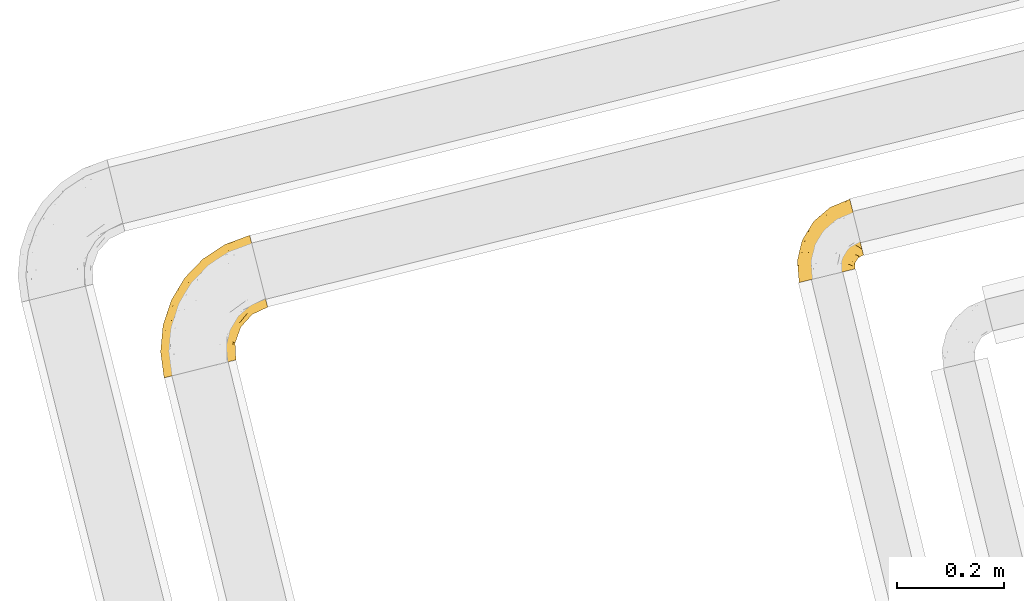
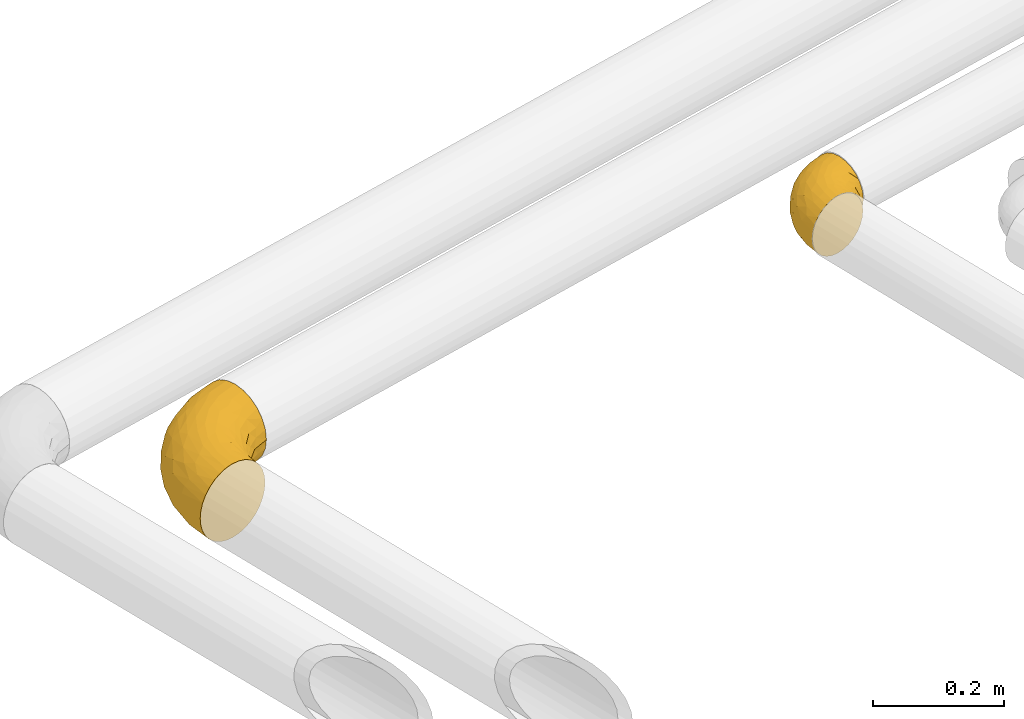
# One storey, part 11 of 93: 2 coverings.
"""IFC2X3 building model written with IfcOpenShell, lengths in millimetres."""

from ifc_helpers import new_model, entity, si_unit, converted_unit, derived_unit, direction, frame, origin, place, context, subcontext, project, spatial, faceted_brep, element, save


model = new_model("IFC2X3")

# Units and contexts
model_context = context("Model", 3, precision=0.01, world=origin(), true_north=direction((6.12303176911189e-17, 1.0)))
body_context = subcontext(model_context, "Body", "Model", "MODEL_VIEW")
ifc_project = project(units=[si_unit("LENGTHUNIT", "METRE", prefix="MILLI"), si_unit("AREAUNIT", "SQUARE_METRE"), si_unit("VOLUMEUNIT", "CUBIC_METRE"), converted_unit("PLANEANGLEUNIT", "DEGREE", entity("IfcRatioMeasure", 0.0174532925199433), si_unit("PLANEANGLEUNIT", "RADIAN"), dimensions=[0, 0, 0, 0, 0, 0, 0]), si_unit("MASSUNIT", "GRAM", prefix="KILO"), derived_unit("MASSDENSITYUNIT", [(si_unit("MASSUNIT", "GRAM", prefix="KILO"), 1), (si_unit("LENGTHUNIT", "METRE"), -3)]), derived_unit("MOMENTOFINERTIAUNIT", [(si_unit("LENGTHUNIT", "METRE"), 4)]), si_unit("TIMEUNIT", "SECOND"), si_unit("FREQUENCYUNIT", "HERTZ"), si_unit("THERMODYNAMICTEMPERATUREUNIT", "DEGREE_CELSIUS"), derived_unit("THERMALTRANSMITTANCEUNIT", [(si_unit("MASSUNIT", "GRAM", prefix="KILO"), 1), (si_unit("THERMODYNAMICTEMPERATUREUNIT", "KELVIN"), -1), (si_unit("TIMEUNIT", "SECOND"), -3)]), derived_unit("VOLUMETRICFLOWRATEUNIT", [(si_unit("LENGTHUNIT", "METRE"), 3), (si_unit("TIMEUNIT", "SECOND"), -1)]), derived_unit("MASSFLOWRATEUNIT", [(si_unit("MASSUNIT", "GRAM", prefix="KILO"), 1), (si_unit("TIMEUNIT", "SECOND"), -1)]), derived_unit("ROTATIONALFREQUENCYUNIT", [(si_unit("TIMEUNIT", "SECOND"), -1)]), si_unit("ELECTRICCURRENTUNIT", "AMPERE"), si_unit("ELECTRICVOLTAGEUNIT", "VOLT"), si_unit("POWERUNIT", "WATT"), si_unit("FORCEUNIT", "NEWTON", prefix="KILO"), si_unit("ILLUMINANCEUNIT", "LUX"), si_unit("LUMINOUSFLUXUNIT", "LUMEN"), si_unit("LUMINOUSINTENSITYUNIT", "CANDELA"), derived_unit("USERDEFINED", [(si_unit("MASSUNIT", "GRAM", prefix="KILO"), -1), (si_unit("LENGTHUNIT", "METRE"), -2), (si_unit("TIMEUNIT", "SECOND"), 3), (si_unit("LUMINOUSFLUXUNIT", "LUMEN"), 1)]), derived_unit("LINEARVELOCITYUNIT", [(si_unit("LENGTHUNIT", "METRE"), 1), (si_unit("TIMEUNIT", "SECOND"), -1)]), si_unit("PRESSUREUNIT", "PASCAL"), derived_unit("USERDEFINED", [(si_unit("LENGTHUNIT", "METRE"), -2), (si_unit("MASSUNIT", "GRAM", prefix="KILO"), 1), (si_unit("TIMEUNIT", "SECOND"), -2)]), derived_unit("LINEARFORCEUNIT", [(si_unit("MASSUNIT", "GRAM", prefix="KILO"), 1), (si_unit("LENGTHUNIT", "METRE"), 1), (si_unit("TIMEUNIT", "SECOND"), -2), (si_unit("LENGTHUNIT", "METRE"), -1)]), derived_unit("PLANARFORCEUNIT", [(si_unit("MASSUNIT", "GRAM", prefix="KILO"), 1), (si_unit("LENGTHUNIT", "METRE"), 1), (si_unit("TIMEUNIT", "SECOND"), -2), (si_unit("LENGTHUNIT", "METRE"), -2)])], contexts=[model_context])

# Site, building, storey
site_placement = place(None, origin())
site = spatial("IfcSite", under=ifc_project, at=site_placement, CompositionType="ELEMENT")
building_placement = place(site_placement, origin())
building = spatial("IfcBuilding", under=site, at=building_placement, CompositionType="ELEMENT")
storey_placement = place(building_placement, frame((0.0, 0.0, -4200.0)))
storey = spatial("IfcBuildingStorey", under=building, at=storey_placement, CompositionType="ELEMENT", Elevation=-4200.0)

# Coverings
covering_1_placement = place(storey_placement, frame((-16617.81, 11360.72, 2429.32)))
element("IfcCovering", 1, at=covering_1_placement, inside=storey, Name=":ADSK_", ObjectType=":ADSK_", PredefinedType="INSULATION", context=body_context, shape_type="Brep", body=[
    faceted_brep([(27.66, 6.48, 119.38), (19.34, 4.41, 108.92), (13.15, 2.87, 96.99), (9.34, 1.92, 84.05), (8.06, 1.6, 70.6), (9.34, 1.92, 57.13), (13.16, 2.87, 44.18), (19.34, 4.41, 32.25), (27.67, 6.49, 21.8), (37.82, 9.02, 13.22), (49.39, 11.9, 6.84), (61.95, 15.03, 2.92), (75.01, 18.29, 1.6), (88.07, 21.55, 2.92), (100.63, 24.68, 6.85), (112.21, 27.56, 13.23), (122.35, 30.09, 21.81), (130.68, 32.17, 32.27), (136.86, 33.71, 44.2), (140.67, 34.66, 57.14), (141.96, 34.98, 70.6), (140.67, 34.66, 84.06), (136.86, 33.71, 97.01), (130.67, 32.17, 108.94), (122.34, 30.09, 119.39), (112.2, 27.56, 127.97), (100.62, 24.67, 134.35), (88.06, 21.54, 138.27), (75.01, 18.29, 139.6), (61.94, 15.03, 138.27), (49.38, 11.9, 134.34), (37.8, 9.01, 127.96), (198.72, 142.14, 36.1), (196.07, 152.78, 21.8), (192.61, 166.65, 10.84), (188.58, 182.79, 3.95), (186.7, 190.35, 2.92), (184.26, 200.12, 1.6), (179.94, 217.45, 3.95), (175.92, 233.6, 10.84), (172.46, 247.46, 21.8), (169.81, 258.1, 36.1), (168.14, 264.79, 52.74), (167.57, 267.07, 70.6), (168.14, 264.79, 88.45), (169.81, 258.1, 105.1), (172.46, 247.46, 119.39), (175.92, 233.6, 130.35), (179.94, 217.45, 137.24), (184.26, 200.12, 139.6), (186.7, 190.35, 138.27), (188.58, 182.79, 137.24), (192.61, 166.65, 130.35), (196.07, 152.78, 119.39), (198.72, 142.14, 105.1), (200.39, 135.45, 88.45), (200.96, 133.17, 70.6), (200.39, 135.45, 52.74), (80.62, 223.04, 70.6), (94.81, 232.4, 83.48), (121.61, 249.95, 70.6), (128.34, 251.82, 83.77), (60.54, 84.03, 138.42), (59.59, 48.09, 138.7), (70.57, 57.19, 139.6), (115.53, 241.59, 95.16), (46.64, 187.68, 70.6), (21.38, 145.64, 70.6), (34.87, 166.15, 88.55), (46.46, 70.33, 134.98), (34.07, 62.13, 129.07), (131.53, 214.73, 131.06), (110.47, 216.17, 122.45), (92.11, 189.92, 129.1), (63.88, 205.82, 83.61), (55.22, 147.52, 127.05), (74.12, 184.86, 122.02), (44.71, 151.47, 117.32), (39.65, 108.08, 127.76), (128.35, 238.9, 110.77), (54.14, 178.89, 108.41), (84.27, 208.01, 111.97), (145.82, 233.08, 124.14), (89.6, 155.91, 137.81), (91.98, 131.83, 139.6), (104.16, 147.15, 139.6), (116.35, 162.48, 139.6), (10.95, 89.14, 99.97), (22.07, 108.68, 111.29), (24.2, 135.36, 100.2), (142.23, 204.2, 136.96), (24.84, 79.64, 120.82), (107.9, 189.12, 134.72), (119.98, 181.7, 138.53), (132.09, 174.12, 139.6), (147.83, 185.77, 139.6), (13.81, 121.67, 85.56), (4.85, 85.24, 83.03), (68.01, 203.39, 98.49), (25.6, 40.79, 122.52), (15.87, 48.45, 112.56), (4.16, 50.71, 89.27), (1.6, 50.21, 70.6), (8.86, 51.21, 101.45), (73.06, 35.38, 139.6), (59.32, 128.79, 133.88), (72.83, 121.4, 138.52), (73.47, 76.56, 139.6), (76.36, 95.92, 139.6), (77.59, 164.24, 132.65), (6.11, 99.04, 70.6), (84.17, 113.88, 139.6), (158.04, 189.79, 139.6), (168.26, 193.82, 139.6), (136.37, 67.44, 94.19), (129.76, 53.94, 106.02), (162.45, 171.59, 136.83), (95.65, 56.81, 134.87), (107.32, 80.2, 130.69), (86.68, 78.41, 138.16), (128.8, 133.71, 133.28), (142.9, 131.05, 126.08), (146.48, 146.13, 131.6), (120.17, 60.65, 118.74), (128.13, 75.11, 111.83), (121.81, 91.54, 123.27), (129.41, 151.89, 137.55), (148.99, 159.57, 135.67), (110.29, 50.65, 127.06), (108.93, 102.01, 133.33), (111.74, 129.23, 137.19), (95.79, 106.47, 137.97), (171.82, 155.75, 128.39), (163.85, 122.49, 101.84), (178.04, 125.7, 86.49), (183.03, 133.25, 99.1), (138.11, 85.23, 100.79), (158.88, 109.83, 86.27), (135.48, 95.69, 111.58), (172.37, 119.69, 70.6), (151.12, 96.29, 70.6), (169.02, 138.92, 116.89), (144.83, 88.41, 86.82), (140.44, 66.55, 70.6), (85.37, 42.83, 138.09), (146.9, 120.39, 116.82), (147.53, 102.49, 99.48), (123.26, 115.61, 129.97), (132.17, 108.77, 121.73), (157.74, 141.91, 125.02), (143.29, 90.33, 47.08), (154.25, 106.81, 49.2), (107.7, 68.0, 11.95), (96.92, 51.72, 6.82), (92.37, 81.84, 4.25), (168.73, 119.6, 53.51), (157.29, 117.18, 38.34), (178.78, 131.41, 41.46), (171.82, 155.75, 12.8), (166.39, 137.69, 23.89), (146.48, 146.13, 9.59), (107.88, 95.25, 8.56), (121.57, 78.45, 21.21), (140.05, 106.42, 27.96), (141.23, 124.14, 17.86), (153.79, 124.17, 27.1), (135.82, 57.93, 48.02), (129.8, 70.63, 32.97), (183.7, 129.24, 53.08), (131.25, 89.06, 27.99), (120.7, 55.5, 23.19), (130.17, 50.25, 35.67), (85.38, 42.84, 3.1), (162.45, 171.59, 4.37), (176.26, 196.97, 1.6), (147.83, 185.77, 1.6), (168.26, 193.82, 1.6), (138.24, 163.46, 2.93), (132.09, 174.12, 1.6), (123.96, 146.26, 3.68), (124.47, 100.29, 17.11), (121.62, 124.69, 7.87), (111.29, 46.6, 14.69), (84.3, 63.94, 2.91), (70.57, 57.19, 1.6), (73.06, 35.38, 1.6), (95.32, 109.04, 2.92), (76.36, 95.92, 1.6), (84.17, 113.88, 1.6), (91.98, 131.83, 1.6), (73.47, 76.56, 1.6), (106.98, 128.07, 3.18), (104.16, 147.15, 1.6), (116.35, 162.48, 1.6), (90.11, 155.74, 3.26), (69.46, 122.71, 3.41), (61.03, 132.13, 7.26), (36.84, 94.34, 12.98), (35.14, 53.42, 11.38), (24.85, 79.65, 20.36), (22.1, 108.75, 29.89), (15.88, 48.46, 28.62), (10.96, 89.18, 41.21), (151.59, 201.48, 2.7), (51.33, 53.64, 4.33), (24.19, 135.37, 41.0), (60.86, 83.69, 2.7), (103.02, 236.55, 52.64), (132.45, 253.79, 57.93), (136.93, 251.76, 45.26), (13.81, 121.67, 55.63), (122.65, 236.15, 30.68), (132.63, 211.56, 8.42), (25.61, 40.8, 18.66), (63.88, 205.82, 57.58), (68.01, 203.39, 42.7), (115.79, 184.23, 3.64), (108.97, 235.23, 41.02), (34.87, 166.15, 52.64), (44.02, 171.36, 39.64), (33.24, 117.03, 20.5), (48.52, 91.07, 6.62), (140.19, 230.96, 17.3), (101.64, 210.45, 19.21), (103.38, 189.76, 7.94), (71.28, 177.86, 17.12), (78.85, 162.39, 7.56), (6.3, 86.93, 52.86), (9.58, 38.2, 39.53), (4.17, 50.73, 51.91), (44.74, 151.51, 23.86), (69.03, 191.86, 28.24), (51.91, 138.11, 13.13), (90.48, 216.82, 33.14)], [[[0, 1, 2, 3, 4, 5, 6, 7, 8, 9, 10, 11, 12, 13, 14, 15, 16, 17, 18, 19, 20, 21, 22, 23, 24, 25, 26, 27, 28, 29, 30, 31]], [[32, 33, 34, 35, 36, 37, 38, 39, 40, 41, 42, 43, 44, 45, 46, 47, 48, 49, 50, 51, 52, 53, 54, 55, 56, 57]], [[58, 59, 60]], [[61, 43, 60]], [[62, 63, 64]], [[44, 65, 45]], [[66, 67, 68]], [[69, 70, 30]], [[71, 72, 73]], [[58, 74, 59]], [[75, 76, 77]], [[74, 58, 66]], [[77, 78, 75]], [[79, 46, 45]], [[80, 76, 81]], [[79, 45, 65]], [[47, 46, 82]], [[83, 84, 85, 86]], [[87, 88, 89]], [[49, 48, 90]], [[91, 70, 78]], [[90, 92, 93]], [[93, 86, 94, 95]], [[87, 96, 97]], [[74, 68, 98]], [[78, 70, 69]], [[70, 91, 99]], [[0, 99, 100]], [[2, 101, 3]], [[102, 101, 97]], [[81, 79, 65]], [[1, 100, 103]], [[68, 96, 89]], [[2, 1, 103]], [[59, 61, 60]], [[102, 4, 3]], [[86, 93, 83]], [[99, 0, 31]], [[68, 89, 80]], [[63, 69, 29]], [[63, 28, 104, 64]], [[92, 90, 71]], [[101, 103, 87]], [[69, 30, 29]], [[105, 62, 106]], [[62, 64, 107, 108]], [[88, 100, 91]], [[83, 106, 84]], [[1, 0, 100]], [[109, 83, 92]], [[96, 67, 110]], [[96, 68, 67]], [[106, 108, 111, 84]], [[102, 3, 101]], [[105, 69, 62]], [[90, 95, 112, 113, 49]], [[83, 93, 92]], [[97, 96, 110]], [[89, 96, 87]], [[95, 90, 93]], [[71, 48, 47]], [[48, 71, 90]], [[82, 71, 47]], [[81, 65, 98]], [[82, 79, 72]], [[31, 30, 70]], [[100, 99, 91]], [[70, 99, 31]], [[78, 69, 105]], [[75, 78, 105]], [[88, 78, 77]], [[87, 100, 88]], [[77, 76, 80]], [[78, 88, 91]], [[77, 89, 88]], [[68, 74, 66]], [[59, 98, 65]], [[105, 109, 75]], [[73, 76, 75]], [[75, 109, 73]], [[81, 76, 72]], [[79, 81, 72]], [[81, 98, 80]], [[83, 109, 105]], [[109, 92, 73]], [[68, 80, 98]], [[89, 77, 80]], [[98, 59, 74]], [[59, 65, 61]], [[65, 44, 61]], [[43, 61, 44]], [[71, 73, 92]], [[72, 76, 73]], [[69, 63, 62]], [[28, 63, 29]], [[105, 106, 83]], [[108, 106, 62]], [[79, 82, 46]], [[71, 82, 72]], [[2, 103, 101]], [[100, 87, 103]], [[102, 97, 110]], [[87, 97, 101]], [[22, 114, 115]], [[116, 112, 95]], [[116, 51, 112]], [[117, 118, 119]], [[52, 51, 116]], [[120, 121, 122]], [[123, 124, 125]], [[94, 126, 127]], [[117, 25, 128]], [[129, 130, 131]], [[124, 123, 115]], [[53, 52, 132]], [[133, 134, 135]], [[84, 131, 130]], [[114, 136, 124]], [[56, 55, 134]], [[134, 133, 137]], [[124, 136, 138]], [[139, 137, 140]], [[54, 53, 141]], [[123, 23, 115]], [[94, 86, 126]], [[24, 128, 25]], [[142, 143, 140]], [[117, 26, 25]], [[123, 24, 23]], [[132, 141, 53]], [[26, 144, 27]], [[144, 104, 27]], [[23, 22, 115]], [[133, 141, 145]], [[118, 128, 123]], [[143, 21, 20]], [[143, 114, 21]], [[141, 133, 135]], [[136, 142, 146]], [[119, 144, 117]], [[137, 142, 140]], [[21, 114, 22]], [[119, 131, 108]], [[118, 117, 128]], [[126, 85, 130]], [[26, 117, 144]], [[128, 24, 123]], [[107, 144, 119]], [[116, 127, 132]], [[107, 119, 108]], [[64, 144, 107]], [[131, 84, 111, 108]], [[119, 118, 131]], [[131, 118, 129]], [[125, 118, 123]], [[138, 146, 145]], [[147, 120, 130]], [[120, 126, 130]], [[114, 124, 115]], [[124, 138, 125]], [[148, 138, 145]], [[129, 125, 147]], [[116, 132, 52]], [[132, 122, 149]], [[121, 149, 122]], [[125, 148, 147]], [[134, 137, 139]], [[133, 145, 146]], [[146, 142, 137]], [[143, 142, 114]], [[133, 146, 137]], [[136, 146, 138]], [[56, 134, 139]], [[134, 55, 135]], [[55, 54, 135]], [[141, 135, 54]], [[104, 144, 64]], [[104, 28, 27]], [[142, 136, 114]], [[50, 49, 113, 112, 51]], [[116, 95, 94]], [[125, 129, 118]], [[130, 129, 147]], [[147, 148, 121]], [[126, 120, 122]], [[127, 126, 122]], [[138, 148, 125]], [[147, 121, 120]], [[149, 145, 141]], [[145, 149, 121]], [[132, 149, 141]], [[132, 127, 122]], [[94, 127, 116]], [[85, 126, 86]], [[85, 84, 130]], [[121, 148, 145]], [[140, 150, 151]], [[152, 153, 154]], [[155, 156, 157]], [[158, 159, 160]], [[152, 161, 162]], [[163, 164, 165]], [[166, 167, 150]], [[155, 168, 139]], [[167, 162, 169]], [[170, 167, 171]], [[13, 172, 14]], [[155, 151, 156]], [[34, 173, 35]], [[174, 37, 36, 35, 175, 176]], [[143, 19, 166]], [[34, 33, 158]], [[143, 150, 140]], [[173, 177, 178]], [[33, 32, 159]], [[166, 150, 143]], [[160, 179, 177]], [[143, 20, 19]], [[161, 180, 162]], [[179, 160, 181]], [[171, 166, 18]], [[32, 57, 157]], [[18, 166, 19]], [[15, 182, 16]], [[16, 170, 17]], [[153, 15, 14]], [[161, 152, 154]], [[183, 172, 184]], [[170, 162, 167]], [[153, 152, 182]], [[181, 164, 180]], [[180, 161, 181]], [[182, 170, 16]], [[184, 172, 185]], [[172, 13, 185]], [[157, 159, 32]], [[164, 163, 180]], [[186, 187, 188, 189]], [[18, 17, 171]], [[158, 173, 34]], [[183, 153, 172]], [[170, 171, 17]], [[166, 171, 167]], [[190, 187, 183, 184]], [[153, 14, 172]], [[183, 187, 154]], [[139, 168, 56]], [[157, 156, 165]], [[153, 182, 15]], [[170, 182, 152]], [[168, 155, 157]], [[140, 155, 139]], [[154, 186, 161]], [[160, 159, 164]], [[191, 161, 186]], [[191, 192, 179]], [[187, 186, 154]], [[191, 186, 189]], [[159, 158, 33]], [[173, 158, 160]], [[160, 164, 181]], [[165, 164, 159]], [[156, 150, 163]], [[169, 150, 167]], [[13, 12, 185]], [[152, 162, 170]], [[169, 180, 163]], [[180, 169, 162]], [[150, 169, 163]], [[154, 153, 183]], [[179, 181, 191]], [[177, 179, 193]], [[178, 175, 173]], [[160, 177, 173]], [[177, 193, 178]], [[161, 191, 181]], [[140, 151, 155]], [[150, 156, 151]], [[175, 35, 173]], [[157, 57, 168]], [[56, 168, 57]], [[157, 165, 159]], [[163, 165, 156]], [[192, 191, 189]], [[192, 193, 179]], [[194, 195, 196]], [[197, 198, 199]], [[200, 201, 202]], [[203, 37, 174, 176, 175]], [[198, 204, 10]], [[200, 202, 205]], [[206, 187, 190, 184]], [[189, 195, 194]], [[58, 60, 207]], [[8, 7, 201]], [[43, 42, 208]], [[209, 207, 208]], [[67, 210, 110]], [[211, 41, 40]], [[205, 202, 210]], [[203, 212, 38]], [[213, 198, 9]], [[214, 207, 215]], [[216, 175, 178, 193]], [[207, 209, 217]], [[218, 219, 205]], [[200, 220, 199]], [[195, 206, 221]], [[198, 221, 204]], [[210, 67, 218]], [[222, 40, 39]], [[12, 11, 204]], [[221, 206, 204]], [[198, 10, 9]], [[221, 197, 196]], [[66, 214, 218]], [[223, 224, 225]], [[203, 175, 216]], [[195, 189, 188, 187]], [[194, 226, 216]], [[213, 201, 199]], [[58, 214, 66]], [[67, 66, 218]], [[110, 210, 227]], [[213, 9, 8]], [[202, 201, 228]], [[5, 102, 229]], [[4, 102, 5]], [[230, 231, 225]], [[231, 219, 215]], [[5, 229, 6]], [[228, 6, 229]], [[38, 212, 39]], [[227, 102, 110]], [[225, 232, 230]], [[7, 6, 228]], [[40, 222, 211]], [[41, 209, 42]], [[223, 231, 233]], [[211, 217, 209]], [[205, 210, 218]], [[229, 227, 202]], [[226, 224, 216]], [[222, 212, 223]], [[201, 213, 8]], [[198, 213, 199]], [[219, 218, 215]], [[200, 199, 201]], [[205, 230, 200]], [[220, 200, 230]], [[207, 214, 58]], [[218, 214, 215]], [[233, 215, 217]], [[230, 205, 219]], [[225, 231, 223]], [[230, 219, 231]], [[224, 223, 212]], [[232, 225, 226]], [[196, 232, 226]], [[220, 197, 199]], [[230, 232, 220]], [[232, 196, 197]], [[232, 197, 220]], [[198, 197, 221]], [[212, 222, 39]], [[211, 222, 223]], [[187, 206, 195]], [[204, 184, 185, 12]], [[184, 204, 206]], [[204, 11, 10]], [[211, 209, 41]], [[208, 207, 60]], [[43, 208, 60]], [[42, 209, 208]], [[233, 217, 211]], [[215, 207, 217]], [[223, 233, 211]], [[215, 233, 231]], [[212, 203, 216]], [[37, 203, 38]], [[216, 193, 194]], [[194, 193, 192, 189]], [[202, 228, 229]], [[7, 228, 201]], [[227, 229, 102]], [[210, 202, 227]], [[225, 224, 226]], [[212, 216, 224]], [[194, 196, 226]], [[221, 196, 195]]]),
])
covering_2_placement = place(storey_placement, frame((-15431.94, 11538.15, 2445.74)))
element("IfcCovering", 2, at=covering_2_placement, inside=storey, Name=":ADSK_", ObjectType=":ADSK_", PredefinedType="INSULATION", context=body_context, shape_type="Brep", body=[
    faceted_brep([(10.03, 2.85, 78.3), (6.19, 1.91, 66.99), (4.89, 1.6, 55.09), (6.19, 1.91, 43.18), (10.04, 2.85, 31.87), (16.24, 4.36, 21.73), (24.47, 6.37, 13.26), (34.33, 8.77, 6.89), (45.31, 11.45, 2.93), (56.87, 14.27, 1.6), (64.99, 16.25, 2.54), (68.44, 17.09, 2.94), (73.93, 18.43, 4.92), (79.43, 19.76, 6.9), (89.28, 22.17, 13.27), (97.51, 24.17, 21.75), (103.7, 25.68, 31.89), (107.54, 26.62, 43.2), (108.85, 26.94, 55.1), (107.54, 26.62, 67.01), (103.69, 25.68, 78.32), (97.5, 24.17, 88.46), (89.27, 22.16, 96.93), (79.41, 19.76, 103.3), (68.42, 17.08, 107.26), (64.99, 16.25, 107.65), (56.87, 14.27, 108.6), (45.3, 11.44, 107.25), (34.31, 8.77, 103.29), (24.45, 6.36, 96.92), (16.22, 4.36, 88.44), (115.25, 91.44, 3.42), (113.96, 96.74, 2.7), (112.97, 100.81, 2.15), (111.97, 104.89, 1.6), (108.69, 118.35, 3.42), (105.64, 130.88, 8.76), (103.01, 141.65, 17.27), (101.0, 149.91, 28.35), (99.73, 155.1, 41.25), (99.3, 156.87, 55.1), (99.73, 155.1, 68.94), (101.0, 149.91, 81.85), (103.01, 141.65, 92.93), (105.64, 130.88, 101.43), (108.69, 118.35, 106.77), (111.97, 104.89, 108.6), (113.96, 96.74, 107.49), (115.25, 91.44, 106.77), (118.31, 78.9, 101.43), (120.93, 68.14, 92.93), (121.94, 64.01, 87.39), (122.94, 59.88, 81.85), (124.21, 54.69, 68.94), (124.64, 52.92, 55.1), (124.21, 54.69, 41.25), (122.94, 59.88, 28.35), (121.94, 64.01, 22.81), (120.93, 68.14, 17.27), (118.31, 78.9, 8.76), (21.29, 97.96, 55.1), (10.84, 80.79, 55.09), (22.64, 97.14, 73.24), (31.73, 115.14, 55.1), (62.21, 141.36, 55.1), (69.2, 144.47, 64.31), (74.72, 146.59, 55.1), (43.27, 124.31, 69.72), (56.23, 127.02, 83.86), (71.49, 142.79, 73.75), (80.0, 139.8, 85.97), (45.01, 34.7, 107.7), (56.87, 93.28, 104.64), (81.76, 118.54, 102.95), (56.41, 108.89, 98.54), (84.92, 106.5, 107.25), (74.7, 127.77, 95.18), (14.69, 35.78, 90.51), (23.79, 30.06, 98.73), (22.55, 58.25, 95.26), (48.34, 64.59, 107.07), (55.62, 43.5, 108.6), (58.12, 50.37, 108.6), (60.63, 57.25, 108.6), (63.14, 64.12, 108.6), (65.65, 70.99, 108.6), (39.26, 80.14, 101.0), (3.68, 32.7, 71.07), (66.45, 87.45, 107.81), (70.6, 76.38, 108.6), (75.54, 81.77, 108.6), (80.49, 87.16, 108.6), (85.44, 92.55, 108.6), (5.92, 61.78, 66.18), (9.79, 57.09, 79.65), (8.63, 25.74, 81.96), (2.71, 28.15, 55.09), (29.42, 97.84, 84.07), (39.05, 114.97, 78.92), (15.42, 78.56, 77.86), (56.47, 23.49, 108.6), (56.08, 32.71, 108.6), (19.67, 74.67, 86.88), (33.29, 54.72, 102.87), (33.32, 30.79, 104.12), (33.54, 90.05, 93.41), (45.85, 111.01, 90.38), (46.97, 128.25, 55.1), (1.6, 41.66, 55.09), (95.23, 97.1, 108.6), (99.41, 99.05, 108.6), (103.6, 101.0, 108.6), (6.22, 61.23, 55.09), (110.0, 44.03, 68.06), (107.58, 47.02, 78.21), (103.67, 40.92, 79.79), (102.7, 87.85, 107.0), (106.54, 79.6, 103.83), (93.75, 84.56, 107.38), (107.81, 63.77, 94.28), (114.82, 60.31, 86.9), (100.72, 57.72, 94.45), (91.03, 65.39, 102.96), (93.5, 51.58, 96.54), (102.21, 49.16, 87.49), (83.36, 40.22, 100.74), (70.8, 46.98, 106.68), (73.54, 34.5, 105.2), (109.35, 71.83, 99.2), (116.31, 50.66, 67.53), (117.75, 56.14, 78.56), (88.44, 30.39, 96.67), (95.87, 36.15, 89.6), (64.85, 25.16, 107.7), (65.49, 31.62, 107.5), (103.98, 32.79, 76.02), (107.34, 35.8, 66.38), (110.12, 53.41, 82.45), (80.57, 49.36, 103.46), (71.97, 54.73, 107.01), (96.96, 43.96, 90.49), (64.58, 39.13, 107.75), (109.1, 38.06, 55.1), (114.88, 47.57, 55.1), (97.67, 76.25, 104.56), (86.2, 80.3, 107.65), (80.38, 72.78, 107.45), (101.37, 69.29, 100.58), (108.95, 31.53, 55.1), (89.06, 44.99, 97.74), (78.74, 58.31, 105.61), (75.47, 66.86, 107.55), (117.76, 56.14, 31.63), (112.02, 58.76, 23.17), (80.21, 72.7, 2.72), (75.54, 81.77, 1.6), (86.18, 80.2, 2.55), (116.31, 50.66, 42.67), (56.47, 23.49, 1.6), (56.08, 32.71, 1.6), (55.62, 43.5, 1.6), (65.51, 31.61, 2.69), (110.0, 44.02, 42.14), (78.75, 58.29, 4.59), (91.04, 65.39, 7.23), (93.53, 51.59, 13.66), (95.89, 36.15, 20.61), (103.68, 40.93, 30.42), (103.99, 32.8, 34.19), (107.79, 102.95, 1.6), (95.23, 97.1, 1.6), (103.6, 101.0, 1.6), (109.39, 71.93, 10.94), (101.51, 69.33, 9.65), (97.67, 76.25, 5.63), (106.44, 79.71, 6.3), (93.6, 84.55, 2.79), (102.7, 87.85, 3.19), (73.56, 34.51, 5.0), (85.44, 92.55, 1.6), (101.87, 56.65, 17.25), (101.56, 48.48, 22.43), (107.81, 63.77, 15.91), (65.65, 70.99, 1.6), (107.35, 35.8, 43.82), (110.12, 53.42, 27.75), (88.46, 30.39, 13.54), (96.18, 43.95, 18.9), (83.38, 40.23, 9.46), (70.82, 46.99, 3.52), (64.6, 39.14, 2.44), (58.13, 50.37, 1.6), (88.21, 45.87, 11.66), (70.44, 55.98, 2.75), (63.14, 64.12, 1.6), (107.35, 47.21, 31.37), (80.49, 87.16, 1.6), (79.38, 49.45, 6.2), (70.6, 76.38, 1.6), (60.63, 57.25, 1.6), (66.45, 87.45, 2.38), (74.69, 127.76, 15.01), (81.76, 118.54, 7.24), (56.4, 108.88, 11.66), (33.55, 90.04, 16.77), (39.27, 80.13, 9.18), (22.56, 58.25, 14.92), (19.68, 74.67, 23.29), (48.35, 64.59, 3.11), (84.92, 106.5, 2.94), (69.2, 144.47, 45.89), (71.49, 142.79, 36.44), (56.88, 93.27, 5.55), (33.31, 54.71, 7.31), (80.0, 139.79, 24.22), (56.22, 127.01, 26.33), (9.8, 57.09, 30.52), (3.68, 32.71, 39.1), (5.93, 61.79, 43.99), (29.44, 97.85, 26.11), (45.02, 34.7, 2.49), (22.65, 97.14, 36.95), (14.71, 35.78, 19.67), (23.81, 30.06, 11.45), (43.27, 124.31, 40.47), (15.43, 78.56, 32.32), (8.64, 25.75, 28.22), (45.83, 110.97, 19.8), (33.33, 30.8, 6.06), (39.04, 114.97, 31.27)], [[[0, 1, 2, 3, 4, 5, 6, 7, 8, 9, 10, 11, 12, 13, 14, 15, 16, 17, 18, 19, 20, 21, 22, 23, 24, 25, 26, 27, 28, 29, 30]], [[31, 32, 33, 34, 35, 36, 37, 38, 39, 40, 41, 42, 43, 44, 45, 46, 47, 48, 49, 50, 51, 52, 53, 54, 55, 56, 57, 58, 59]], [[60, 61, 62, 63]], [[64, 65, 66]], [[67, 68, 69]], [[69, 68, 70]], [[71, 27, 26]], [[72, 73, 74]], [[42, 41, 69]], [[45, 73, 75]], [[43, 76, 44]], [[70, 43, 42]], [[77, 78, 79]], [[78, 29, 28]], [[80, 81, 82, 83, 84, 85]], [[46, 45, 75]], [[86, 72, 74]], [[0, 87, 1]], [[88, 85, 89, 90, 91, 92]], [[93, 87, 94]], [[78, 77, 29]], [[73, 44, 76]], [[87, 0, 95]], [[43, 70, 76]], [[0, 30, 95]], [[87, 96, 1]], [[88, 80, 85]], [[97, 98, 62]], [[99, 97, 62]], [[77, 30, 29]], [[71, 26, 100, 101, 81]], [[77, 79, 102]], [[41, 66, 65]], [[103, 104, 71]], [[103, 78, 104]], [[44, 73, 45]], [[97, 105, 106]], [[94, 87, 95]], [[65, 107, 67]], [[94, 77, 102]], [[93, 108, 87]], [[86, 80, 72]], [[69, 70, 42]], [[67, 69, 65]], [[67, 63, 62]], [[30, 77, 95]], [[94, 95, 77]], [[104, 78, 28]], [[79, 78, 103]], [[86, 79, 103]], [[79, 105, 102]], [[74, 73, 76]], [[72, 88, 75]], [[106, 76, 68]], [[86, 74, 105]], [[72, 75, 73]], [[75, 92, 109, 110, 111, 46]], [[81, 80, 71]], [[103, 71, 80]], [[93, 94, 99]], [[93, 61, 112, 108]], [[28, 27, 104]], [[71, 104, 27]], [[96, 87, 108]], [[96, 2, 1]], [[76, 70, 68]], [[75, 88, 92]], [[80, 88, 72]], [[41, 40, 66]], [[62, 98, 67]], [[41, 65, 69]], [[97, 102, 105]], [[99, 94, 102]], [[106, 105, 74]], [[67, 98, 68]], [[76, 106, 74]], [[98, 106, 68]], [[97, 99, 102]], [[93, 99, 62]], [[79, 86, 105]], [[80, 86, 103]], [[62, 61, 93]], [[107, 65, 64]], [[107, 63, 67]], [[106, 98, 97]], [[113, 114, 115]], [[109, 92, 116]], [[117, 116, 118]], [[48, 109, 116]], [[119, 120, 51]], [[121, 122, 123]], [[123, 124, 121]], [[125, 126, 127]], [[100, 26, 25, 24]], [[117, 128, 49]], [[129, 54, 53]], [[130, 53, 52]], [[131, 132, 125]], [[133, 23, 134]], [[115, 135, 136]], [[137, 130, 120]], [[138, 139, 126]], [[115, 124, 140]], [[21, 20, 132]], [[22, 131, 127]], [[22, 127, 23]], [[134, 127, 141]], [[135, 19, 136]], [[113, 142, 143]], [[144, 145, 146]], [[128, 147, 119]], [[148, 142, 136]], [[133, 100, 24]], [[149, 132, 140]], [[114, 129, 137]], [[47, 46, 111, 110, 109, 48]], [[20, 135, 132]], [[135, 20, 19]], [[122, 150, 123]], [[21, 131, 22]], [[134, 81, 101]], [[128, 50, 49]], [[118, 116, 92]], [[141, 81, 134]], [[48, 116, 49]], [[129, 113, 143]], [[115, 114, 124]], [[19, 18, 148]], [[118, 145, 144]], [[146, 151, 122]], [[151, 84, 139]], [[144, 146, 122]], [[138, 149, 123]], [[19, 148, 136]], [[132, 135, 115]], [[142, 113, 136]], [[115, 136, 113]], [[54, 129, 143]], [[129, 53, 130]], [[133, 134, 101]], [[23, 127, 134]], [[138, 125, 149]], [[126, 82, 141]], [[132, 131, 21]], [[127, 131, 125]], [[118, 91, 145]], [[117, 118, 144]], [[117, 144, 128]], [[116, 117, 49]], [[147, 128, 144]], [[128, 119, 51]], [[144, 122, 147]], [[145, 90, 146]], [[146, 90, 89]], [[146, 89, 151]], [[91, 118, 92]], [[91, 90, 145]], [[121, 147, 122]], [[120, 130, 52]], [[129, 130, 137]], [[120, 52, 51]], [[120, 119, 121]], [[51, 50, 128]], [[137, 120, 121]], [[140, 124, 123]], [[137, 121, 124]], [[121, 119, 147]], [[149, 140, 123]], [[115, 140, 132]], [[138, 123, 150]], [[132, 149, 125]], [[139, 138, 150]], [[126, 125, 138]], [[84, 151, 85]], [[83, 126, 139]], [[129, 114, 113]], [[137, 124, 114]], [[127, 126, 141]], [[100, 133, 101]], [[82, 126, 83]], [[82, 81, 141]], [[23, 133, 24]], [[151, 89, 85]], [[122, 151, 150]], [[139, 150, 151]], [[84, 83, 139]], [[56, 152, 153]], [[154, 155, 156]], [[54, 143, 157]], [[10, 9, 158, 159, 11]], [[160, 161, 159]], [[143, 142, 162]], [[163, 164, 165]], [[166, 167, 168]], [[169, 34, 33, 32, 31, 170, 171]], [[172, 173, 174]], [[172, 175, 59]], [[175, 176, 177]], [[178, 14, 13]], [[179, 170, 177]], [[165, 180, 181]], [[182, 180, 164]], [[18, 17, 148]], [[163, 183, 154]], [[17, 168, 184]], [[153, 185, 180]], [[177, 31, 59]], [[15, 14, 186]], [[16, 15, 166]], [[165, 181, 187]], [[178, 188, 186]], [[188, 178, 189]], [[56, 55, 152]], [[190, 191, 189]], [[161, 160, 190]], [[12, 159, 161]], [[56, 153, 57]], [[143, 162, 157]], [[187, 192, 165]], [[17, 16, 168]], [[175, 172, 174]], [[186, 166, 15]], [[31, 177, 170]], [[163, 193, 194]], [[175, 177, 59]], [[181, 195, 167]], [[185, 152, 157]], [[142, 148, 184]], [[184, 148, 17]], [[156, 164, 154]], [[192, 163, 165]], [[176, 156, 196]], [[192, 197, 163]], [[166, 168, 16]], [[184, 167, 162]], [[167, 184, 168]], [[162, 142, 184]], [[157, 162, 195]], [[54, 157, 55]], [[178, 13, 161]], [[12, 11, 159]], [[190, 178, 161]], [[197, 193, 163]], [[178, 186, 14]], [[166, 186, 188]], [[172, 59, 58]], [[176, 175, 174]], [[172, 58, 57]], [[173, 172, 182]], [[156, 176, 174]], [[177, 176, 179]], [[164, 156, 174]], [[196, 179, 176]], [[163, 154, 164]], [[154, 183, 198, 155]], [[156, 155, 196]], [[182, 164, 173]], [[164, 174, 173]], [[157, 152, 55]], [[153, 152, 185]], [[181, 185, 195]], [[172, 57, 182]], [[164, 180, 165]], [[182, 153, 180]], [[185, 181, 180]], [[187, 167, 166]], [[157, 195, 185]], [[162, 167, 195]], [[167, 187, 181]], [[192, 166, 188]], [[166, 192, 187]], [[192, 188, 197]], [[188, 189, 197]], [[193, 197, 189]], [[189, 199, 193]], [[194, 183, 163]], [[193, 199, 194]], [[57, 153, 182]], [[191, 199, 189]], [[189, 178, 190]], [[190, 160, 191]], [[161, 13, 12]], [[200, 179, 196, 155, 198, 183]], [[201, 202, 203]], [[204, 203, 205]], [[204, 206, 207]], [[208, 183, 194, 199, 191, 160]], [[209, 34, 169, 171, 170, 179]], [[202, 36, 35]], [[202, 201, 36]], [[210, 39, 211]], [[200, 208, 212]], [[205, 208, 213]], [[214, 211, 38]], [[38, 211, 39]], [[214, 201, 215]], [[216, 217, 218]], [[201, 37, 36]], [[207, 219, 204]], [[213, 208, 220]], [[220, 160, 159, 158, 9]], [[221, 61, 60, 63]], [[9, 8, 220]], [[217, 4, 3]], [[5, 222, 6]], [[218, 108, 112, 61]], [[217, 3, 96]], [[222, 223, 6]], [[224, 211, 215]], [[218, 221, 225]], [[5, 4, 226]], [[223, 206, 213]], [[226, 4, 217]], [[108, 217, 96]], [[212, 202, 209]], [[201, 203, 227]], [[226, 216, 222]], [[207, 206, 222]], [[214, 38, 37]], [[6, 223, 7]], [[7, 223, 228]], [[39, 210, 66]], [[224, 107, 210]], [[224, 215, 229]], [[107, 64, 210]], [[216, 226, 217]], [[222, 5, 226]], [[206, 223, 222]], [[228, 223, 213]], [[207, 222, 216]], [[205, 206, 204]], [[209, 202, 35]], [[203, 202, 212]], [[205, 203, 212]], [[204, 219, 227]], [[34, 209, 35]], [[209, 179, 200]], [[220, 8, 228]], [[208, 160, 220]], [[108, 218, 217]], [[218, 61, 221]], [[220, 228, 213]], [[8, 7, 228]], [[3, 2, 96]], [[201, 214, 37]], [[211, 214, 215]], [[208, 200, 183]], [[209, 200, 212]], [[66, 210, 64]], [[66, 40, 39]], [[224, 210, 211]], [[216, 225, 207]], [[207, 225, 219]], [[229, 221, 224]], [[204, 227, 203]], [[229, 227, 219]], [[201, 227, 215]], [[218, 225, 216]], [[219, 225, 221]], [[208, 205, 212]], [[206, 205, 213]], [[221, 63, 224]], [[224, 63, 107]], [[227, 229, 215]], [[221, 229, 219]]]),
])

save(model, "model.ifc")
